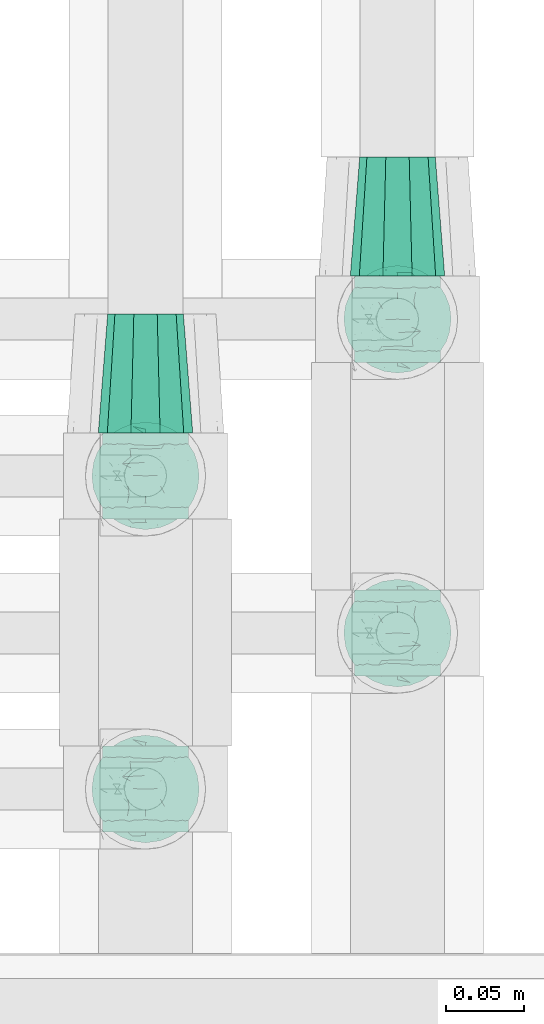
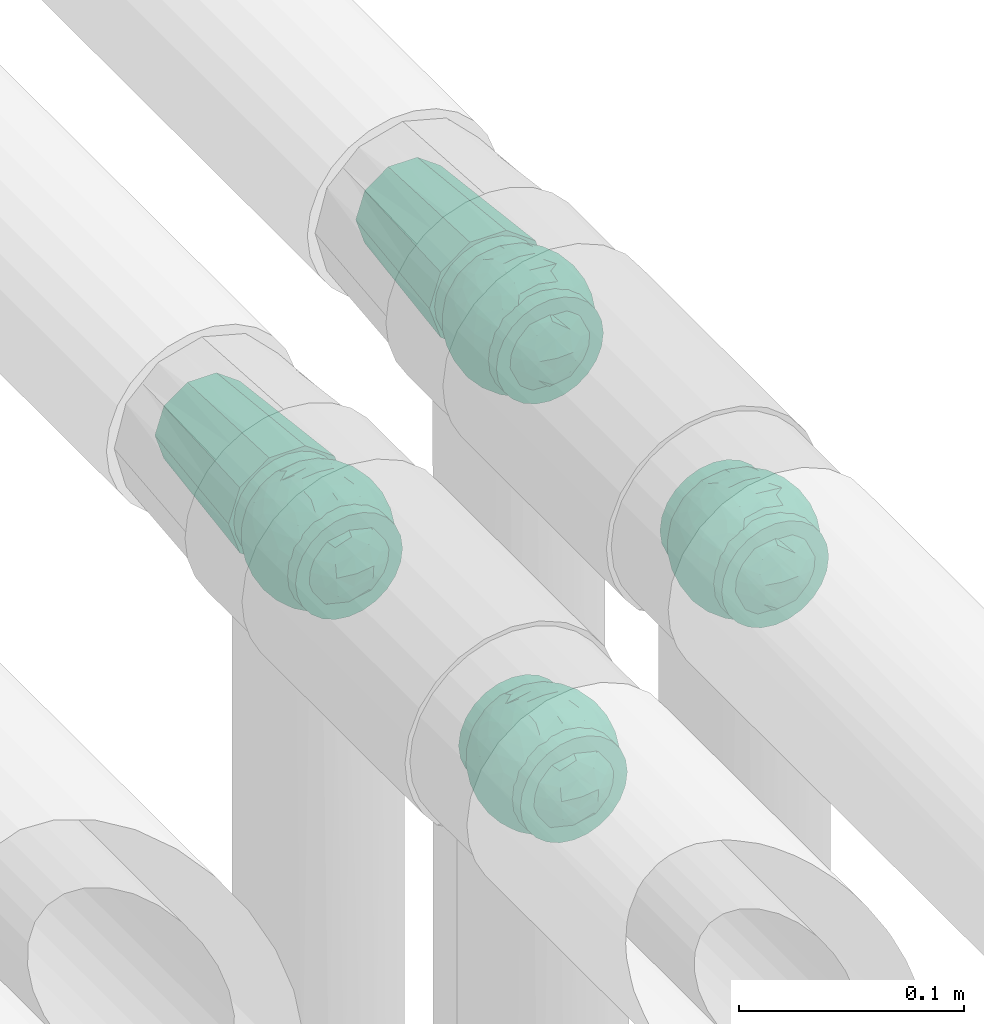
# One storey, part 647 of 827: 6 flow fittings.
"""IFC2X3 building model written with IfcOpenShell, lengths in millimetres."""

from ifc_helpers import new_model, entity, si_unit, converted_unit, derived_unit, direction, frame, origin, place, context, subcontext, project, spatial, faceted_brep, source, transform, mapped, material, material_list, type_object, type_shapes, element, save


model = new_model("IFC2X3")

# Units and contexts
model_context = context("Model", 3, precision=0.01, world=origin(), true_north=direction((6.12303176911189e-17, 1.0)))
body_context = subcontext(model_context, "Body", "Model", "MODEL_VIEW")
ifc_project = project(units=[si_unit("LENGTHUNIT", "METRE", prefix="MILLI"), si_unit("AREAUNIT", "SQUARE_METRE"), si_unit("VOLUMEUNIT", "CUBIC_METRE"), converted_unit("PLANEANGLEUNIT", "DEGREE", entity("IfcRatioMeasure", 0.0174532925199433), si_unit("PLANEANGLEUNIT", "RADIAN"), dimensions=[0, 0, 0, 0, 0, 0, 0]), si_unit("MASSUNIT", "GRAM", prefix="KILO"), derived_unit("MASSDENSITYUNIT", [(si_unit("MASSUNIT", "GRAM", prefix="KILO"), 1), (si_unit("LENGTHUNIT", "METRE"), -3)]), derived_unit("MOMENTOFINERTIAUNIT", [(si_unit("LENGTHUNIT", "METRE"), 4)]), si_unit("TIMEUNIT", "SECOND"), si_unit("FREQUENCYUNIT", "HERTZ"), si_unit("THERMODYNAMICTEMPERATUREUNIT", "DEGREE_CELSIUS"), derived_unit("THERMALTRANSMITTANCEUNIT", [(si_unit("MASSUNIT", "GRAM", prefix="KILO"), 1), (si_unit("THERMODYNAMICTEMPERATUREUNIT", "KELVIN"), -1), (si_unit("TIMEUNIT", "SECOND"), -3)]), derived_unit("VOLUMETRICFLOWRATEUNIT", [(si_unit("LENGTHUNIT", "METRE"), 3), (si_unit("TIMEUNIT", "SECOND"), -1)]), derived_unit("MASSFLOWRATEUNIT", [(si_unit("MASSUNIT", "GRAM", prefix="KILO"), 1), (si_unit("TIMEUNIT", "SECOND"), -1)]), derived_unit("ROTATIONALFREQUENCYUNIT", [(si_unit("TIMEUNIT", "SECOND"), -1)]), si_unit("ELECTRICCURRENTUNIT", "AMPERE"), si_unit("ELECTRICVOLTAGEUNIT", "VOLT"), si_unit("POWERUNIT", "WATT"), si_unit("FORCEUNIT", "NEWTON", prefix="KILO"), si_unit("ILLUMINANCEUNIT", "LUX"), si_unit("LUMINOUSFLUXUNIT", "LUMEN"), si_unit("LUMINOUSINTENSITYUNIT", "CANDELA"), derived_unit("USERDEFINED", [(si_unit("MASSUNIT", "GRAM", prefix="KILO"), -1), (si_unit("LENGTHUNIT", "METRE"), -2), (si_unit("TIMEUNIT", "SECOND"), 3), (si_unit("LUMINOUSFLUXUNIT", "LUMEN"), 1)]), derived_unit("LINEARVELOCITYUNIT", [(si_unit("LENGTHUNIT", "METRE"), 1), (si_unit("TIMEUNIT", "SECOND"), -1)]), si_unit("PRESSUREUNIT", "PASCAL"), derived_unit("USERDEFINED", [(si_unit("LENGTHUNIT", "METRE"), -2), (si_unit("MASSUNIT", "GRAM", prefix="KILO"), 1), (si_unit("TIMEUNIT", "SECOND"), -2)]), derived_unit("LINEARFORCEUNIT", [(si_unit("MASSUNIT", "GRAM", prefix="KILO"), 1), (si_unit("LENGTHUNIT", "METRE"), 1), (si_unit("TIMEUNIT", "SECOND"), -2), (si_unit("LENGTHUNIT", "METRE"), -1)]), derived_unit("PLANARFORCEUNIT", [(si_unit("MASSUNIT", "GRAM", prefix="KILO"), 1), (si_unit("LENGTHUNIT", "METRE"), 1), (si_unit("TIMEUNIT", "SECOND"), -2), (si_unit("LENGTHUNIT", "METRE"), -2)])], contexts=[model_context])

# Site, building, storey
site_placement = place(None, origin())
site = spatial("IfcSite", under=ifc_project, at=site_placement, CompositionType="ELEMENT")
building_placement = place(site_placement, origin())
building = spatial("IfcBuilding", under=site, at=building_placement, CompositionType="ELEMENT")
storey_placement = place(building_placement, frame((0.0, 0.0, 28200.0)))
storey = spatial("IfcBuildingStorey", under=building, at=storey_placement, Name="08", CompositionType="ELEMENT", Elevation=28200.0)

# Flow fittings
ifc_material_1 = material()
pipe_fitting_type_1 = type_object("IfcPipeFittingType", Name="ADSK_1", PredefinedType="NOTDEFINED", material=ifc_material_1)
shared_shape_1 = source(origin(), body_context, "Body", "Brep", [
    faceted_brep([(76.0, 7.46, 22.97), (76.0, 0.0, 22.97), (76.0, -7.46, 22.97), (76.0, -13.5, 18.58), (76.0, -19.54, 14.2), (76.0, -21.84, 7.1), (76.0, -24.15, 0.0), (76.0, -21.84, -7.1), (76.0, -19.54, -14.2), (76.0, -13.5, -18.58), (76.0, -7.46, -22.97), (76.0, 0.0, -22.97), (76.0, 7.46, -22.97), (76.0, 13.5, -18.58), (76.0, 19.54, -14.2), (76.0, 21.84, -7.1), (76.0, 24.15, 0.0), (76.0, 21.84, 7.1), (76.0, 19.54, 14.2), (76.0, 13.5, 18.58), (0.0, -9.32, 28.67), (0.0, 0.0, 28.67), (0.0, 9.32, 28.67), (0.0, 16.85, 23.2), (0.0, 24.39, 17.72), (0.0, 27.27, 8.86), (0.0, 30.15, 0.0), (0.0, 28.24, -5.87), (0.0, 26.33, -11.75), (0.0, 24.39, -17.72), (0.0, 16.85, -23.2), (0.0, 9.32, -28.67), (0.0, 0.0, -28.67), (0.0, -9.32, -28.67), (0.0, -16.85, -23.2), (0.0, -24.39, -17.72), (0.0, -27.27, -8.86), (0.0, -30.15, 0.0), (0.0, -28.24, 5.87), (0.0, -26.33, 11.75), (0.0, -24.39, 17.72), (0.0, -16.85, 23.2)], [[[0, 1, 2, 3, 4, 5, 6, 7, 8, 9, 10, 11, 12, 13, 14, 15, 16, 17, 18, 19]], [[20, 21, 22, 23, 24, 25, 26, 27, 28, 29, 30, 31, 32, 33, 34, 35, 36, 37, 38, 39, 40, 41]], [[35, 8, 7, 6, 37, 36]], [[10, 33, 32, 31, 12, 11]], [[10, 9, 8, 35, 34, 33]], [[15, 14, 29, 28, 27, 26, 16]], [[31, 30, 29, 14, 13, 12]], [[24, 18, 17, 16, 26, 25]], [[0, 22, 21, 20, 2, 1]], [[0, 19, 18, 24, 23, 22]], [[5, 4, 40, 39, 38, 37, 6]], [[20, 41, 40, 4, 3, 2]]]),
])
type_shapes(pipe_fitting_type_1, [shared_shape_1])
flow_fitting_1_placement = place(storey_placement, frame((36629.64, 15617.54, 3550.0), z_axis=(0.0, 0.0, 1.0), x_axis=(0.0, 1.0, 0.0)))
element("IfcFlowFitting", 1, at=flow_fitting_1_placement, inside=storey, type_object=pipe_fitting_type_1, material=ifc_material_1, Name="ADSK_1", ObjectType="ADSK_1", context=body_context, shape_type="MappedRepresentation", body=[
    mapped(shared_shape_1, transform((0.0, 0.0, 0.0), scale=1.0)),
])
ifc_material_2 = material(Name="ADSK_")
ifc_material_list = material_list([ifc_material_1, ifc_material_2])
pipe_fitting_type_2 = type_object("IfcPipeFittingType", Name="ADSK_1", PredefinedType="NOTDEFINED", material=ifc_material_list)
shared_shape_2 = source(origin(), body_context, "Body", "Brep", [
    faceted_brep([(-27.5, 13.75, -23.82), (-27.5, 7.12, -26.56), (-27.5, 0.0, -27.5), (-27.5, -7.12, -26.56), (-27.5, -13.75, -23.82), (-27.5, -19.45, -19.45), (-27.5, -23.82, -13.75), (-27.5, -26.56, -7.12), (-27.5, -27.03, -3.56), (-27.5, -27.5, 0.0), (-27.5, -27.03, 3.56), (-27.5, -26.56, 7.12), (-27.5, -23.82, 13.75), (-27.5, -19.45, 19.45), (-27.5, -13.75, 23.82), (-27.5, -7.12, 26.56), (-27.5, 0.0, 27.5), (-27.5, 7.12, 26.56), (-27.5, 13.75, 23.82), (-27.5, 19.45, 19.45), (-27.5, 23.82, 13.75), (-27.5, 26.56, 7.12), (-27.5, 27.5, 0.0), (-27.5, 26.56, -7.12), (-27.5, 23.82, -13.75), (-27.5, 19.45, -19.45), (27.5, 0.0, -27.5), (27.5, 7.12, -26.56), (27.5, 13.75, -23.82), (27.5, 19.45, -19.45), (27.5, 23.82, -13.75), (27.5, 26.56, -7.12), (27.5, 27.5, 0.0), (27.5, 26.56, 7.12), (27.5, 23.82, 13.75), (27.5, 19.45, 19.45), (27.5, 13.75, 23.82), (27.5, 7.12, 26.56), (27.5, 0.0, 27.5), (27.5, -7.12, 26.56), (27.5, -13.75, 23.82), (27.5, -19.45, 19.45), (27.5, -23.82, 13.75), (27.5, -26.56, 7.12), (27.5, -27.03, 3.56), (27.5, -27.5, 0.0), (27.5, -27.03, -3.56), (27.5, -26.56, -7.12), (27.5, -23.82, -13.75), (27.5, -19.45, -19.45), (27.5, -13.75, -23.82), (27.5, -7.12, -26.56), (11.73, -27.16, 4.32), (12.5, -27.5, 0.0), (-12.5, -27.5, 0.0), (9.56, -26.29, 8.05), (2.2, -24.59, 12.31), (6.28, -25.29, 10.81), (-11.73, -27.16, 4.32), (-9.56, -26.3, 8.05), (-6.28, -25.29, 10.81), (-2.2, -24.59, 12.3), (11.73, -27.16, -4.32), (-11.73, -27.16, -4.32), (2.2, -24.59, -12.31), (6.28, -25.29, -10.81), (9.56, -26.29, -8.05), (-2.2, -24.59, -12.3), (-6.28, -25.29, -10.81), (-9.56, -26.3, -8.05), (0.0, -32.5, -12.5), (3.24, -32.5, -12.07), (6.25, -32.5, -10.83), (8.84, -32.5, -8.84), (10.83, -32.5, -6.25), (12.07, -32.5, -3.24), (12.5, -32.5, 0.0), (12.07, -32.5, 3.24), (10.83, -32.5, 6.25), (8.84, -32.5, 8.84), (6.25, -32.5, 10.83), (3.24, -32.5, 12.07), (0.0, -32.5, 12.5), (-3.24, -32.5, 12.07), (-6.25, -32.5, 10.83), (-8.84, -32.5, 8.84), (-10.83, -32.5, 6.25), (-12.07, -32.5, 3.24), (-12.5, -32.5, 0.0), (-12.07, -32.5, -3.24), (-10.83, -32.5, -6.25), (-8.84, -32.5, -8.84), (-6.25, -32.5, -10.83), (-3.24, -32.5, -12.07)], [[[0, 1, 2, 3, 4, 5, 6, 7, 8, 9, 10, 11, 12, 13, 14, 15, 16, 17, 18, 19, 20, 21, 22, 23, 24, 25]], [[26, 27, 28, 29, 30, 31, 32, 33, 34, 35, 36, 37, 38, 39, 40, 41, 42, 43, 44, 45, 46, 47, 48, 49, 50, 51]], [[44, 43, 52]], [[53, 45, 44]], [[9, 54, 10]], [[43, 55, 52]], [[42, 41, 56]], [[55, 43, 57]], [[56, 57, 42]], [[41, 13, 56]], [[57, 43, 42]], [[58, 11, 10]], [[58, 10, 54]], [[58, 59, 11]], [[60, 61, 12]], [[12, 11, 60]], [[12, 61, 13]], [[60, 11, 59]], [[61, 56, 13]], [[53, 44, 52]], [[41, 40, 14, 13]], [[16, 15, 39, 38]], [[15, 14, 40, 39]], [[17, 16, 38, 37]], [[34, 33, 21, 20]], [[19, 18, 36, 35]], [[20, 19, 35, 34]], [[37, 36, 18, 17]], [[22, 21, 33, 32]], [[22, 32, 31, 23]], [[31, 30, 24, 23]], [[62, 47, 46]], [[29, 25, 24, 30]], [[3, 2, 26, 51]], [[1, 0, 28, 27]], [[26, 2, 1, 27]], [[51, 50, 4, 3]], [[29, 28, 0, 25]], [[54, 8, 63]], [[50, 49, 5, 4]], [[49, 48, 64]], [[65, 64, 48]], [[48, 47, 65]], [[49, 64, 5]], [[45, 53, 46]], [[8, 54, 9]], [[62, 66, 47]], [[62, 46, 53]], [[47, 66, 65]], [[67, 68, 6]], [[6, 5, 67]], [[68, 7, 6]], [[67, 5, 64]], [[69, 63, 7]], [[63, 8, 7]], [[69, 7, 68]], [[70, 71, 72, 73, 74, 75, 76, 77, 78, 79, 80, 81, 82, 83, 84, 85, 86, 87, 88, 89, 90, 91, 92, 93]], [[54, 88, 87]], [[58, 86, 85]], [[87, 86, 54]], [[85, 84, 58]], [[54, 86, 58]], [[59, 58, 83]], [[61, 60, 57]], [[59, 55, 60]], [[83, 82, 59]], [[84, 83, 58]], [[81, 55, 82]], [[80, 52, 81]], [[52, 79, 78]], [[80, 79, 52]], [[53, 78, 77]], [[57, 56, 61]], [[55, 57, 60]], [[78, 53, 52]], [[52, 55, 81]], [[53, 77, 76]], [[59, 82, 55]], [[76, 75, 53]], [[73, 72, 62]], [[74, 73, 62]], [[75, 74, 53]], [[53, 74, 62]], [[66, 62, 71]], [[64, 65, 67]], [[66, 68, 65]], [[71, 70, 66]], [[72, 71, 62]], [[93, 92, 63]], [[70, 93, 69]], [[90, 89, 54]], [[91, 90, 63]], [[92, 91, 63]], [[68, 67, 65]], [[69, 68, 66]], [[90, 54, 63]], [[63, 69, 93]], [[54, 89, 88]], [[66, 70, 69]]]),
    faceted_brep([(32.2, -7.13, -9.68), (29.99, -14.45, -8.59), (28.94, -9.49, -15.93), (-8.59, -32.07, 0.0), (-12.24, -30.73, -9.36), (-7.79, -30.03, -14.79), (-17.25, -5.35, -29.25), (-22.1, 0.0, -26.33), (-14.53, 1.93, -31.09), (5.64, -28.03, -19.09), (12.03, -30.43, -10.55), (6.89, -31.78, -11.15), (33.03, 0.02, -9.53), (31.5, 11.29, -7.89), (32.07, 8.59, 0.0), (18.49, 10.45, -27.03), (9.79, 9.53, -31.54), (13.36, 17.84, -26.17), (26.69, -17.93, -12.17), (26.62, -20.33, 0.0), (-13.79, -26.06, -17.66), (-7.65, -24.14, -23.25), (25.78, 8.63, -21.03), (28.11, 16.02, -11.6), (30.96, 4.98, -14.07), (-5.29, 32.51, -9.84), (-8.59, 32.07, 0.0), (-4.3, 33.22, 0.0), (-30.96, -4.98, -14.07), (-27.23, -2.54, -20.83), (-28.05, -13.51, -14.57), (-32.09, 6.5, -10.47), (-32.07, 8.59, 0.0), (-30.7, 12.98, -8.39), (20.59, -17.7, -21.08), (15.5, -17.52, -25.18), (14.77, -11.61, -28.79), (-31.5, -11.29, -7.89), (-33.33, 0.45, -8.39), (-30.33, 2.3, -16.02), (-26.49, 4.56, -21.43), (-27.59, 17.57, -10.57), (-28.94, 9.49, -15.93), (-6.14, 4.52, -33.52), (-3.39, 12.98, -31.65), (2.0, 6.75, -33.65), (-22.07, 22.74, -13.32), (-17.46, 22.99, -18.67), (-17.43, 16.87, -24.35), (-12.41, 10.69, -30.22), (-20.18, 8.8, -26.4), (-27.06, -19.27, -8.83), (-22.66, -23.72, -10.27), (-23.48, -23.48, 0.0), (-23.82, -8.76, -23.18), (-24.13, 14.95, -19.39), (-23.48, 23.48, 0.0), (-17.19, 29.77, 0.0), (-9.64, 18.57, -27.27), (-18.9, -22.8, -17.45), (-17.43, -27.94, -9.86), (-12.43, -19.14, -25.71), (4.45, 15.58, -30.31), (8.5, 1.01, -33.29), (15.43, -3.58, -30.51), (8.21, -7.67, -32.49), (4.3, 33.22, 0.0), (8.59, 32.07, 0.0), (6.64, 32.34, -9.57), (17.19, 29.77, 0.0), (22.32, 24.3, -9.63), (17.37, 27.38, -11.41), (21.36, -9.17, -25.32), (-8.57, -3.29, -33.13), (-0.3, -12.2, -32.13), (-11.86, -10.52, -30.5), (30.42, -2.35, -15.83), (26.35, -4.32, -21.64), (27.7, 2.28, -20.22), (0.58, -30.75, -15.35), (-29.77, 17.19, 0.0), (-26.62, 20.33, 0.0), (11.01, 30.24, -12.08), (12.37, 25.55, -19.39), (4.3, -33.22, 0.0), (-0.26, -33.45, -7.91), (6.44, 22.33, -25.33), (6.01, 27.87, -19.21), (-17.49, 27.84, -10.04), (-13.19, 27.01, -16.68), (-0.95, 26.5, -21.87), (0.58, 30.75, -15.35), (12.89, 30.92, 0.0), (-5.22, -32.56, -9.7), (8.22, -17.52, -28.41), (-1.31, -20.75, -27.38), (-0.97, -26.5, -21.87), (12.89, -30.92, 0.0), (17.37, -27.3, -11.61), (17.19, -29.77, 0.0), (-12.89, 30.92, 0.0), (-12.24, 30.74, -9.31), (-6.93, 29.68, -15.9), (-7.67, 25.17, -22.11), (-18.4, -12.91, -26.01), (0.2, -2.63, -34.27), (30.92, -12.89, 0.0), (22.1, 0.0, -26.33), (23.48, -23.48, 0.0), (22.32, -24.3, -9.63), (25.48, -10.29, -20.66), (-1.31, 20.75, -27.38), (17.68, 22.07, -19.54), (22.49, 17.3, -19.4), (15.09, 4.11, -30.61), (23.48, 23.48, 0.0), (26.62, 20.33, 0.0), (29.77, 17.19, 0.0), (-0.26, 33.45, -7.91), (0.0, 34.37, 0.0), (-6.75, -15.55, -29.91), (7.07, -23.3, -24.26), (11.83, -26.3, -18.72), (16.59, -22.63, -19.85), (-22.55, -17.29, -19.34), (-26.62, -20.33, 0.0), (-34.37, 0.0, 0.0), (-32.07, -8.59, 0.0), (-29.77, -17.19, 0.0), (0.0, -34.38, 0.0), (-4.3, -33.22, 0.0), (-17.19, -29.77, 0.0), (-12.89, -30.92, 0.0), (8.59, -32.07, 0.0), (32.07, -8.59, 0.0), (30.92, 12.89, 0.0), (34.38, 0.0, 0.0), (29.77, -17.19, 0.0), (-27.59, -17.57, 10.57), (-28.94, -9.49, 15.93), (-30.7, -12.98, 8.39), (-12.24, 30.73, 9.36), (-7.79, 30.03, 14.79), (-17.25, 5.35, 29.25), (-22.1, 0.0, 26.33), (-14.53, -1.93, 31.09), (-27.23, 2.54, 20.83), (-30.33, -2.3, 16.02), (-26.49, -4.56, 21.43), (-31.5, 11.29, 7.89), (-33.33, -0.45, 8.39), (-30.96, 4.98, 14.07), (-27.06, 19.27, 8.83), (-22.66, 23.72, 10.27), (26.69, 17.93, 12.17), (29.99, 14.45, 8.59), (-13.79, 26.06, 17.66), (-7.65, 24.14, 23.25), (-28.05, 13.51, 14.57), (-5.29, -32.51, 9.84), (30.96, -4.98, 14.07), (25.78, -8.63, 21.03), (28.11, -16.02, 11.6), (-32.09, -6.5, 10.47), (20.59, 17.7, 21.08), (15.5, 17.52, 25.18), (14.77, 11.6, 28.79), (33.03, -0.02, 9.53), (31.5, -11.29, 7.89), (5.64, 28.03, 19.09), (12.03, 30.43, 10.55), (6.89, 31.78, 11.15), (32.2, 7.13, 9.68), (28.94, 9.49, 15.93), (-6.14, -4.52, 33.52), (-3.39, -12.98, 31.65), (2.0, -6.75, 33.65), (-22.07, -22.74, 13.32), (-17.46, -22.99, 18.67), (-17.43, -16.87, 24.35), (-12.41, -10.69, 30.22), (-20.18, -8.8, 26.4), (9.79, -9.53, 31.54), (13.36, -17.84, 26.17), (18.49, -10.45, 27.03), (-23.82, 8.76, 23.18), (-24.13, -14.95, 19.39), (-9.64, -18.57, 27.27), (-18.9, 22.8, 17.45), (-17.43, 27.94, 9.86), (-12.43, 19.14, 25.71), (4.45, -15.58, 30.31), (8.5, -1.01, 33.29), (15.43, 3.58, 30.51), (8.21, 7.67, 32.49), (6.64, -32.34, 9.57), (22.32, -24.3, 9.63), (17.37, -27.38, 11.41), (21.36, 9.17, 25.32), (-8.57, 3.29, 33.13), (-0.3, 12.2, 32.13), (-11.86, 10.52, 30.5), (30.42, 2.35, 15.83), (26.35, 4.32, 21.64), (27.7, -2.28, 20.22), (0.58, 30.75, 15.35), (11.01, -30.24, 12.08), (12.37, -25.55, 19.39), (-0.26, 33.45, 7.91), (6.44, -22.33, 25.33), (6.01, -27.87, 19.21), (-17.49, -27.84, 10.04), (-13.19, -27.01, 16.68), (-0.95, -26.5, 21.87), (0.58, -30.75, 15.35), (-5.22, 32.56, 9.7), (8.22, 17.52, 28.41), (-1.31, 20.75, 27.38), (-0.97, 26.5, 21.87), (17.37, 27.3, 11.61), (-12.24, -30.74, 9.31), (-6.93, -29.68, 15.9), (-7.67, -25.17, 22.11), (-18.4, 12.91, 26.01), (0.2, 2.63, 34.27), (22.1, 0.0, 26.33), (22.32, 24.3, 9.63), (25.48, 10.29, 20.66), (-1.31, -20.75, 27.38), (17.68, -22.07, 19.54), (22.49, -17.3, 19.4), (15.09, -4.11, 30.61), (-0.26, -33.45, 7.91), (-6.75, 15.55, 29.91), (7.07, 23.3, 24.26), (11.83, 26.3, 18.72), (16.59, 22.63, 19.85), (-22.55, 17.29, 19.34)], [[[0, 1, 2]], [[3, 4, 5]], [[6, 7, 8]], [[9, 10, 11]], [[12, 13, 14]], [[15, 16, 17]], [[18, 1, 19]], [[20, 21, 5]], [[22, 23, 24]], [[25, 26, 27]], [[28, 29, 30]], [[31, 32, 33]], [[34, 35, 36]], [[37, 38, 28]], [[29, 39, 40]], [[33, 41, 42]], [[43, 44, 45]], [[46, 47, 48]], [[49, 8, 50]], [[51, 52, 53]], [[7, 6, 54]], [[55, 50, 40]], [[46, 56, 57]], [[49, 58, 44]], [[46, 55, 41]], [[52, 59, 60]], [[49, 44, 43]], [[59, 61, 20]], [[62, 16, 45]], [[63, 64, 65]], [[66, 67, 68]], [[69, 70, 71]], [[72, 36, 64]], [[73, 74, 75]], [[76, 77, 78]], [[9, 11, 79]], [[41, 80, 81, 56]], [[82, 71, 83]], [[11, 84, 85]], [[86, 87, 83]], [[88, 89, 47]], [[87, 82, 83]], [[87, 90, 91]], [[71, 82, 92]], [[17, 16, 62]], [[79, 85, 93]], [[74, 94, 95]], [[9, 79, 96]], [[97, 98, 99]], [[100, 26, 101]], [[55, 46, 48]], [[90, 102, 91]], [[102, 103, 89]], [[104, 61, 59]], [[20, 61, 21]], [[8, 7, 50]], [[105, 43, 45]], [[0, 106, 1]], [[107, 15, 22]], [[108, 109, 18]], [[110, 72, 77]], [[50, 55, 48]], [[109, 99, 98]], [[41, 55, 42]], [[49, 50, 48]], [[50, 7, 40]], [[58, 49, 48]], [[49, 43, 8]], [[73, 8, 43]], [[8, 73, 6]], [[58, 48, 47]], [[58, 111, 44]], [[62, 44, 111]], [[44, 62, 45]], [[39, 38, 31]], [[46, 41, 56]], [[111, 86, 62]], [[62, 86, 17]], [[112, 83, 71]], [[15, 17, 113]], [[90, 87, 86]], [[17, 86, 83]], [[22, 15, 113]], [[107, 64, 114]], [[23, 113, 70]], [[24, 76, 78]], [[113, 23, 22]], [[23, 115, 116, 117]], [[13, 12, 24]], [[90, 86, 111]], [[87, 91, 68]], [[68, 118, 66]], [[69, 71, 92]], [[82, 67, 92]], [[70, 69, 115]], [[83, 112, 17]], [[23, 70, 115]], [[112, 70, 113]], [[103, 111, 58]], [[82, 68, 67]], [[90, 103, 102]], [[101, 102, 89]], [[27, 119, 118]], [[27, 118, 25]], [[16, 63, 45]], [[45, 63, 105]], [[74, 105, 65]], [[73, 75, 6]], [[16, 15, 114]], [[105, 63, 65]], [[94, 74, 65]], [[21, 120, 95]], [[65, 64, 36]], [[121, 122, 9]], [[114, 64, 63]], [[72, 64, 107]], [[72, 107, 77]], [[35, 34, 123]], [[34, 36, 72]], [[94, 65, 36]], [[66, 118, 119]], [[25, 91, 102]], [[87, 68, 82]], [[118, 68, 91]], [[70, 112, 71]], [[113, 17, 112]], [[43, 105, 73]], [[74, 73, 105]], [[16, 114, 63]], [[107, 114, 15]], [[91, 25, 118]], [[25, 102, 101]], [[75, 104, 6]], [[6, 104, 54]], [[30, 54, 124]], [[29, 7, 54]], [[53, 125, 51]], [[40, 42, 55]], [[104, 75, 61]], [[37, 30, 51]], [[54, 104, 124]], [[120, 61, 75]], [[61, 120, 21]], [[111, 103, 90]], [[58, 89, 103]], [[30, 29, 54]], [[39, 29, 28]], [[125, 37, 51]], [[40, 39, 42]], [[38, 39, 28]], [[41, 33, 80]], [[32, 38, 126]], [[127, 37, 128]], [[127, 126, 38]], [[7, 29, 40]], [[95, 96, 21]], [[21, 96, 5]], [[85, 129, 130]], [[131, 60, 132]], [[94, 121, 95]], [[5, 96, 79]], [[96, 95, 121]], [[5, 93, 3]], [[9, 122, 10]], [[97, 10, 98]], [[129, 85, 84]], [[11, 133, 84]], [[121, 9, 96]], [[121, 94, 35]], [[122, 123, 98]], [[133, 11, 10]], [[99, 109, 108]], [[123, 109, 98]], [[72, 110, 34]], [[34, 18, 109]], [[1, 18, 2]], [[98, 10, 122]], [[97, 133, 10]], [[93, 85, 130]], [[85, 79, 11]], [[3, 93, 130]], [[79, 93, 5]], [[42, 39, 31]], [[32, 80, 33]], [[123, 122, 121]], [[109, 123, 34]], [[121, 35, 123]], [[94, 36, 35]], [[38, 37, 127]], [[30, 37, 28]], [[30, 124, 51]], [[128, 37, 125]], [[52, 51, 124]], [[59, 52, 124]], [[131, 53, 52]], [[59, 124, 104]], [[59, 20, 60]], [[3, 132, 4]], [[60, 20, 4]], [[52, 60, 131]], [[24, 23, 13]], [[19, 108, 18]], [[12, 134, 0]], [[2, 76, 0]], [[0, 76, 12]], [[77, 76, 2]], [[12, 76, 24]], [[77, 2, 110]], [[78, 107, 22]], [[13, 117, 135, 14]], [[134, 12, 136]], [[107, 78, 77]], [[136, 12, 14]], [[24, 78, 22]], [[1, 137, 19]], [[106, 0, 134]], [[106, 137, 1]], [[23, 117, 13]], [[2, 18, 110]], [[34, 110, 18]], [[60, 4, 132]], [[20, 5, 4]], [[32, 31, 38]], [[42, 31, 33]], [[100, 101, 88]], [[58, 47, 89]], [[88, 46, 57]], [[46, 88, 47]], [[100, 88, 57]], [[101, 26, 25]], [[88, 101, 89]], [[75, 74, 120]], [[95, 120, 74]], [[138, 139, 140]], [[26, 141, 142]], [[143, 144, 145]], [[146, 147, 148]], [[149, 150, 151]], [[56, 152, 153]], [[154, 155, 116]], [[156, 157, 142]], [[146, 158, 151]], [[159, 3, 130]], [[160, 161, 162]], [[163, 127, 140]], [[164, 165, 166]], [[167, 168, 134]], [[169, 170, 171]], [[172, 155, 173]], [[174, 175, 176]], [[177, 178, 179]], [[180, 145, 181]], [[182, 183, 184]], [[144, 143, 185]], [[186, 181, 148]], [[177, 53, 131]], [[180, 187, 175]], [[177, 186, 138]], [[153, 188, 189]], [[180, 175, 174]], [[188, 190, 156]], [[191, 182, 176]], [[192, 193, 194]], [[84, 133, 195]], [[99, 196, 197]], [[198, 166, 193]], [[199, 200, 201]], [[202, 203, 204]], [[169, 171, 205]], [[138, 128, 125, 53]], [[206, 197, 207]], [[171, 66, 208]], [[209, 210, 207]], [[211, 212, 178]], [[210, 206, 207]], [[210, 213, 214]], [[197, 206, 97]], [[183, 182, 191]], [[205, 208, 215]], [[200, 216, 217]], [[169, 205, 218]], [[92, 219, 69]], [[132, 3, 220]], [[186, 177, 179]], [[213, 221, 214]], [[221, 222, 212]], [[223, 190, 188]], [[156, 190, 157]], [[145, 144, 181]], [[224, 174, 176]], [[172, 135, 155]], [[225, 184, 161]], [[115, 226, 154]], [[227, 198, 203]], [[181, 186, 179]], [[226, 69, 219]], [[138, 186, 139]], [[180, 181, 179]], [[181, 144, 148]], [[187, 180, 179]], [[180, 174, 145]], [[199, 145, 174]], [[145, 199, 143]], [[187, 179, 178]], [[187, 228, 175]], [[191, 175, 228]], [[175, 191, 176]], [[147, 150, 163]], [[177, 138, 53]], [[228, 209, 191]], [[191, 209, 183]], [[229, 207, 197]], [[184, 183, 230]], [[213, 210, 209]], [[183, 209, 207]], [[161, 184, 230]], [[225, 193, 231]], [[162, 230, 196]], [[160, 202, 204]], [[230, 162, 161]], [[162, 108, 19, 137]], [[168, 167, 160]], [[213, 209, 228]], [[210, 214, 195]], [[195, 232, 84]], [[99, 197, 97]], [[206, 133, 97]], [[196, 99, 108]], [[207, 229, 183]], [[162, 196, 108]], [[229, 196, 230]], [[222, 228, 187]], [[206, 195, 133]], [[213, 222, 221]], [[220, 221, 212]], [[130, 129, 232]], [[130, 232, 159]], [[182, 192, 176]], [[176, 192, 224]], [[200, 224, 194]], [[199, 201, 143]], [[182, 184, 231]], [[224, 192, 194]], [[216, 200, 194]], [[157, 233, 217]], [[194, 193, 166]], [[234, 235, 169]], [[231, 193, 192]], [[198, 193, 225]], [[198, 225, 203]], [[165, 164, 236]], [[164, 166, 198]], [[216, 194, 166]], [[84, 232, 129]], [[159, 214, 221]], [[210, 195, 206]], [[232, 195, 214]], [[196, 229, 197]], [[230, 183, 229]], [[174, 224, 199]], [[200, 199, 224]], [[182, 231, 192]], [[225, 231, 184]], [[214, 159, 232]], [[159, 221, 220]], [[201, 223, 143]], [[143, 223, 185]], [[158, 185, 237]], [[146, 144, 185]], [[56, 81, 152]], [[148, 139, 186]], [[223, 201, 190]], [[149, 158, 152]], [[185, 223, 237]], [[233, 190, 201]], [[190, 233, 157]], [[228, 222, 213]], [[187, 212, 222]], [[158, 146, 185]], [[147, 146, 151]], [[81, 149, 152]], [[148, 147, 139]], [[150, 147, 151]], [[138, 140, 128]], [[127, 150, 126]], [[32, 149, 80]], [[32, 126, 150]], [[144, 146, 148]], [[217, 218, 157]], [[157, 218, 142]], [[208, 119, 27]], [[57, 189, 100]], [[216, 234, 217]], [[142, 218, 205]], [[218, 217, 234]], [[142, 215, 26]], [[169, 235, 170]], [[92, 170, 219]], [[119, 208, 66]], [[171, 67, 66]], [[234, 169, 218]], [[234, 216, 165]], [[235, 236, 219]], [[67, 171, 170]], [[69, 226, 115]], [[236, 226, 219]], [[198, 227, 164]], [[164, 154, 226]], [[155, 154, 173]], [[219, 170, 235]], [[92, 67, 170]], [[215, 208, 27]], [[208, 205, 171]], [[26, 215, 27]], [[205, 215, 142]], [[139, 147, 163]], [[127, 128, 140]], [[236, 235, 234]], [[226, 236, 164]], [[234, 165, 236]], [[216, 166, 165]], [[150, 149, 32]], [[158, 149, 151]], [[158, 237, 152]], [[80, 149, 81]], [[153, 152, 237]], [[188, 153, 237]], [[57, 56, 153]], [[188, 237, 223]], [[188, 156, 189]], [[26, 100, 141]], [[189, 156, 141]], [[153, 189, 57]], [[160, 162, 168]], [[116, 115, 154]], [[167, 14, 172]], [[173, 202, 172]], [[172, 202, 167]], [[203, 202, 173]], [[167, 202, 160]], [[203, 173, 227]], [[204, 225, 161]], [[168, 137, 106, 134]], [[14, 167, 136]], [[225, 204, 203]], [[136, 167, 134]], [[160, 204, 161]], [[155, 117, 116]], [[135, 172, 14]], [[135, 117, 155]], [[162, 137, 168]], [[173, 154, 227]], [[164, 227, 154]], [[189, 141, 100]], [[156, 142, 141]], [[127, 163, 150]], [[139, 163, 140]], [[132, 220, 211]], [[187, 178, 212]], [[211, 177, 131]], [[177, 211, 178]], [[132, 211, 131]], [[220, 3, 159]], [[211, 220, 212]], [[201, 200, 233]], [[217, 233, 200]]]),
])
type_shapes(pipe_fitting_type_2, [shared_shape_2])
for number, where, z_axis, x_axis, name in (
    (2, (36629.64, 15590.04, 3550.0), (1.0, 0.0, 0.0), (0.0, 1.0, 0.0), "ADSK_1"),
    (3, (36468.72, 15490.0, 3550.0), (-1.0, 0.0, 0.0), (0.0, -1.0, 0.0), "ADSK_1"),
    (4, (36468.72, 15290.0, 3550.0), (-1.0, 0.0, 0.0), (0.0, -1.0, 0.0), "ADSK_1"),
    (5, (36629.64, 15389.6, 3550.0), (1.0, 0.0, 0.0), (0.0, 1.0, 0.0), "ADSK_1"),
):
    element("IfcFlowFitting", number, at=place(storey_placement, frame(where, z_axis=z_axis, x_axis=x_axis)), inside=storey, type_object=pipe_fitting_type_2, material=ifc_material_list, Name=name, ObjectType="ADSK_1", context=body_context, shape_type="MappedRepresentation", body=[
        mapped(shared_shape_2, transform((0.0, 0.0, 0.0), scale=1.0)),
    ])
pipe_fitting_type_3 = type_object("IfcPipeFittingType", Name="ADSK_1", PredefinedType="NOTDEFINED", material=ifc_material_1)
shared_shape_3 = source(origin(), body_context, "Body", "Brep", [
    faceted_brep([(76.0, 24.15, 0.0), (76.0, 21.84, 7.1), (76.0, 19.54, 14.2), (76.0, 13.5, 18.58), (76.0, 7.46, 22.97), (76.0, 0.0, 22.97), (76.0, -7.46, 22.97), (76.0, -13.5, 18.58), (76.0, -19.54, 14.2), (76.0, -21.84, 7.1), (76.0, -24.15, 0.0), (76.0, -21.84, -7.1), (76.0, -19.54, -14.2), (76.0, -13.5, -18.58), (76.0, -7.46, -22.97), (76.0, 0.0, -22.97), (76.0, 7.46, -22.97), (76.0, 13.5, -18.58), (76.0, 19.54, -14.2), (76.0, 21.84, -7.1), (0.0, -30.15, 0.0), (0.0, -27.27, 8.86), (0.0, -24.39, 17.72), (0.0, -16.85, 23.2), (0.0, -9.32, 28.67), (0.0, 0.0, 28.67), (0.0, 9.32, 28.67), (0.0, 16.85, 23.2), (0.0, 24.39, 17.72), (0.0, 26.33, 11.75), (0.0, 28.24, 5.87), (0.0, 30.15, 0.0), (0.0, 27.27, -8.86), (0.0, 24.39, -17.72), (0.0, 16.85, -23.2), (0.0, 9.32, -28.67), (0.0, 0.0, -28.67), (0.0, -9.32, -28.67), (0.0, -16.85, -23.2), (0.0, -24.39, -17.72), (0.0, -26.33, -11.75), (0.0, -28.24, -5.87)], [[[0, 1, 2, 3, 4, 5, 6, 7, 8, 9, 10, 11, 12, 13, 14, 15, 16, 17, 18, 19]], [[20, 21, 22, 23, 24, 25, 26, 27, 28, 29, 30, 31, 32, 33, 34, 35, 36, 37, 38, 39, 40, 41]], [[19, 18, 33, 32, 31, 0]], [[36, 35, 16, 15, 14, 37]], [[35, 34, 33, 18, 17, 16]], [[41, 40, 39, 12, 11, 10, 20]], [[14, 13, 12, 39, 38, 37]], [[9, 8, 22, 21, 20, 10]], [[25, 24, 6, 5, 4, 26]], [[24, 23, 22, 8, 7, 6]], [[30, 29, 28, 2, 1, 0, 31]], [[4, 3, 2, 28, 27, 26]]]),
])
type_shapes(pipe_fitting_type_3, [shared_shape_3])
flow_fitting_2_placement = place(storey_placement, frame((36468.72, 15517.5, 3550.0), z_axis=(0.0, 0.0, 1.0), x_axis=(0.0, 1.0, 0.0)))
element("IfcFlowFitting", 6, at=flow_fitting_2_placement, inside=storey, type_object=pipe_fitting_type_3, material=ifc_material_1, Name="ADSK_1", ObjectType="ADSK_1", context=body_context, shape_type="MappedRepresentation", body=[
    mapped(shared_shape_3, transform((0.0, 0.0, 0.0), scale=1.0)),
])

save(model, "model.ifc")
